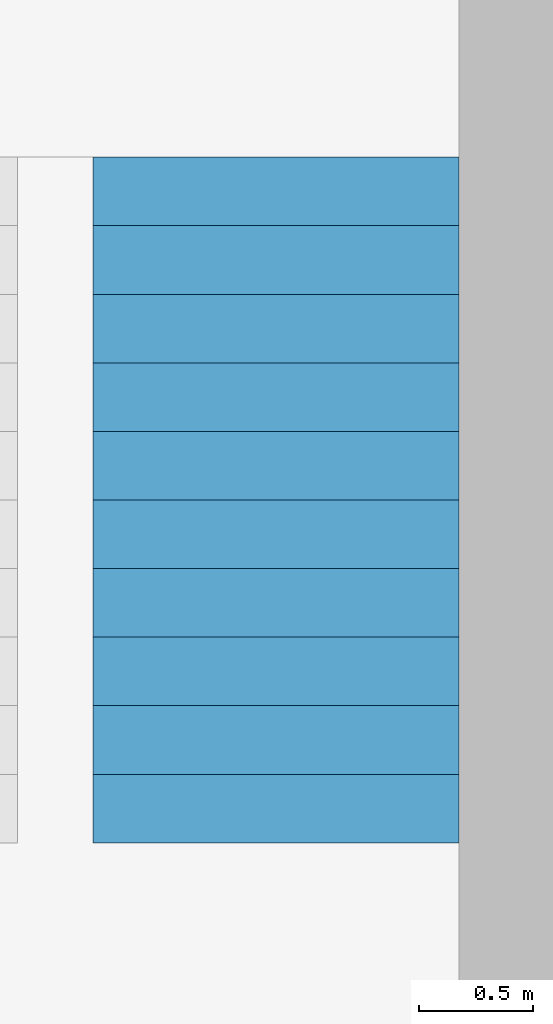
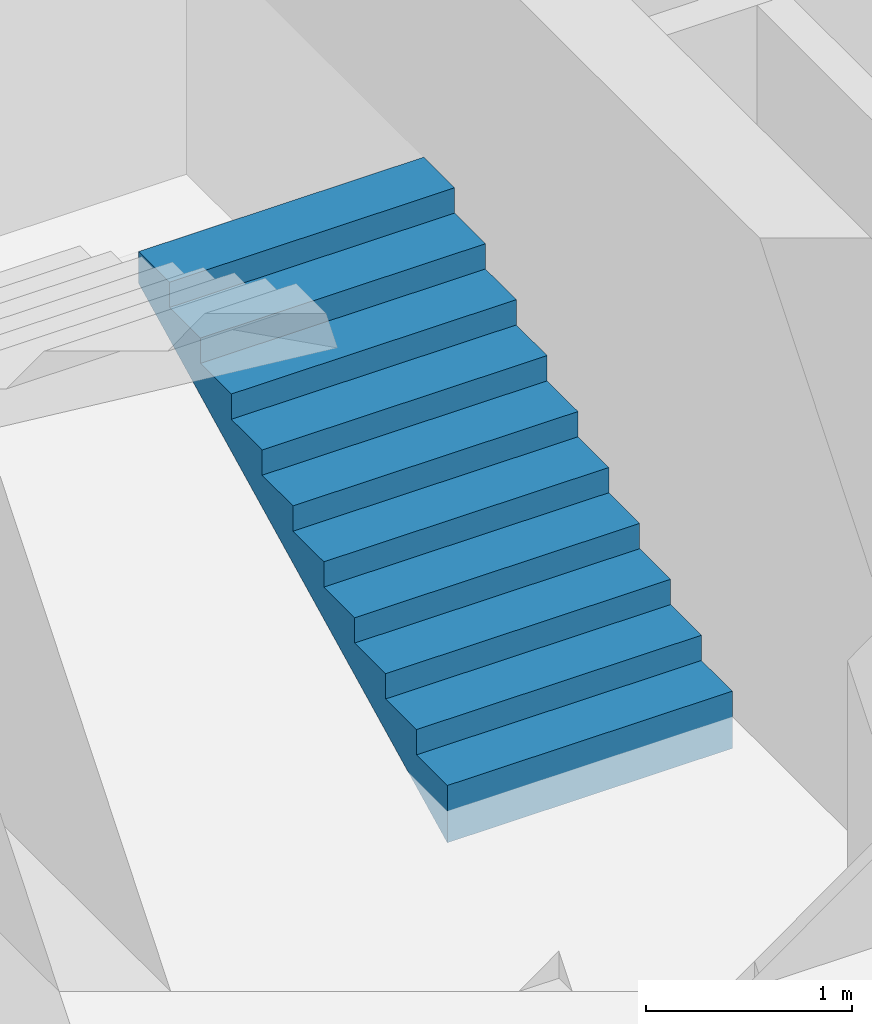
# One storey, part 2 of 5: 1 building element part, 1 element without a shape of its own.
"""IFC4 building model written with IfcOpenShell, lengths in metres."""

from ifc_helpers import new_model, entity, si_unit, converted_unit, derived_unit, direction, frame, origin_with_axes, place, context, subcontext, project, spatial, polygons, material, type_object, element, aggregate, save


model = new_model("IFC4")

# Units and contexts
model_context = context("Model", 3, precision=1e-05, world=origin_with_axes(), true_north=direction((0.0, 1.0)))
body_context = subcontext(model_context, "Body", "Model", "MODEL_VIEW")
ifc_project = project(units=[si_unit("LENGTHUNIT", "METRE"), si_unit("AREAUNIT", "SQUARE_METRE"), si_unit("VOLUMEUNIT", "CUBIC_METRE"), converted_unit("PLANEANGLEUNIT", "DEGREE", entity("IfcPlaneAngleMeasure", 0.0174532925199433), si_unit("PLANEANGLEUNIT", "RADIAN"), dimensions=[0, 0, 0, 0, 0, 0, 0]), converted_unit("TIMEUNIT", "Year", entity("IfcTimeMeasure", 31557600.0), si_unit("TIMEUNIT", "SECOND"), dimensions=[0, 0, 1, 0, 0, 0, 0]), si_unit("MASSUNIT", "GRAM", prefix="KILO"), si_unit("THERMODYNAMICTEMPERATUREUNIT", "DEGREE_CELSIUS"), si_unit("LUMINOUSINTENSITYUNIT", "LUMEN"), si_unit("ENERGYUNIT", "JOULE", prefix="MEGA"), derived_unit("THERMALCONDUCTANCEUNIT", [(si_unit("POWERUNIT", "WATT"), 1), (si_unit("LENGTHUNIT", "METRE"), -1), (si_unit("THERMODYNAMICTEMPERATUREUNIT", "KELVIN"), -1)]), derived_unit("SPECIFICHEATCAPACITYUNIT", [(si_unit("ENERGYUNIT", "JOULE"), 1), (si_unit("MASSUNIT", "GRAM", prefix="KILO"), -1), (si_unit("THERMODYNAMICTEMPERATUREUNIT", "KELVIN"), -1)]), derived_unit("MASSDENSITYUNIT", [(si_unit("MASSUNIT", "GRAM", prefix="KILO"), 1), (si_unit("VOLUMEUNIT", "CUBIC_METRE"), -1)])], contexts=[model_context])

# Site, building, storey
site_placement = place(None, origin_with_axes())
site = spatial("IfcSite", under=ifc_project, at=site_placement, CompositionType="ELEMENT")
building_placement = place(None, origin_with_axes())
building = spatial("IfcBuilding", under=site, at=building_placement, CompositionType="ELEMENT")
storey_placement = place(None, frame((0.0, 0.0, -3.0), z_axis=(0.0, 0.0, 1.0), x_axis=(1.0, 0.0, 0.0)))
storey = spatial("IfcBuildingStorey", under=building, at=storey_placement, Name="UG", CompositionType="ELEMENT", Elevation=-3.0)

# Stair, building element part
stair_type = type_object("IfcStairType", PredefinedType="NOTDEFINED")
stair_placement = place(None, frame((26.388, 9.02499994546755, -3.0), z_axis=(0.0, 0.0, 1.0), x_axis=(1.0, 0.0, 0.0)))
stair = element("IfcStair", 1, at=stair_placement, inside=storey, type_object=stair_type, Name="Treppe - 003", PredefinedType="NOTDEFINED")
ifc_material = material(Name="Stahlbeton Decke")
building_element_part_placement = place(None, frame((26.388, 9.02499994546755, -3.0), z_axis=(0.0, 0.0, 1.0), x_axis=(1.0, 0.0, 0.0)))
building_element_part = element("IfcBuildingElementPart", 2, at=building_element_part_placement, material=ifc_material, Name="Stahlbeton Decke", PredefinedType="NOTDEFINED", context=body_context, shape_type="Tessellation", body=[
    polygons([(1.6, 2.775, 1.19743422191252), (1.6, 2.85, 1.23493422191252), (1.6, 2.925, 1.27243422191252), (1.6, 3.0, 1.30993422191252), (1.6, 3.0, 1.5), (1.6, 2.7, 1.5), (1.6, 2.7, 1.35), (1.6, 2.4, 1.35), (1.6, 2.4, 1.2), (1.6, 2.1, 1.2), (1.6, 2.1, 1.05), (1.6, 1.8, 1.05), (1.6, 1.8, 0.9), (1.6, 1.5, 0.9), (1.6, 1.5, 0.75), (1.6, 1.2, 0.75), (1.6, 1.2, 0.6), (1.6, 0.899999999999999, 0.6), (1.6, 0.899999999999999, 0.45), (1.6, 0.6, 0.45), (1.6, 0.6, 0.3), (1.6, 0.3, 0.3), (1.6, 0.3, 0.15), (1.6, 0.0, 0.15), (1.6, 0.0, -0.190065778087482), (1.6, 0.0999999999999999, -0.140065778087482), (1.6, 0.2, -0.0900657780874821), (1.6, 0.3, -0.0400657780874822), (1.6, 0.4, 0.0099342219125178), (1.6, 0.5, 0.0599342219125178), (1.6, 0.6, 0.109934221912518), (1.6, 0.7, 0.159934221912518), (1.6, 0.8, 0.209934221912518), (1.6, 0.899999999999999, 0.259934221912518), (1.6, 0.975, 0.297434221912518), (1.6, 1.05, 0.334934221912518), (1.6, 1.125, 0.372434221912518), (1.6, 1.2, 0.409934221912518), (1.6, 1.275, 0.447434221912518), (1.6, 1.35, 0.484934221912518), (1.6, 1.425, 0.522434221912518), (1.6, 1.5, 0.559934221912518), (1.6, 1.575, 0.597434221912518), (1.6, 1.65, 0.634934221912518), (1.6, 1.725, 0.672434221912518), (1.6, 1.8, 0.709934221912518), (1.6, 1.9, 0.759934221912518), (1.6, 2.0, 0.809934221912518), (1.6, 2.1, 0.859934221912518), (1.6, 2.2, 0.909934221912518), (1.6, 2.3, 0.959934221912518), (1.6, 2.4, 1.00993422191252), (1.6, 2.5, 1.05993422191252), (1.6, 2.6, 1.10993422191252), (1.6, 2.7, 1.15993422191252), (0.0, 2.775, 1.19743422191252), (0.0, 2.85, 1.23493422191252), (0.0, 2.925, 1.27243422191252), (0.0, 3.0, 1.30993422191252), (0.0, 3.0, 1.5), (0.0, 2.7, 1.5), (0.0, 2.7, 1.35), (0.0, 2.4, 1.35), (0.0, 2.4, 1.2), (0.0, 2.1, 1.2), (0.0, 2.1, 1.05), (0.0, 1.8, 1.05), (0.0, 1.8, 0.9), (0.0, 1.5, 0.9), (0.0, 1.5, 0.75), (0.0, 1.2, 0.75), (0.0, 1.2, 0.6), (0.0, 0.899999999999999, 0.6), (0.0, 0.899999999999999, 0.45), (0.0, 0.6, 0.45), (0.0, 0.6, 0.3), (0.0, 0.3, 0.3), (0.0, 0.3, 0.15), (0.0, 0.0, 0.15), (0.0, 0.0, -0.190065778087482), (0.0, 0.0999999999999999, -0.140065778087482), (0.0, 0.2, -0.0900657780874821), (0.0, 0.3, -0.0400657780874822), (0.0, 0.4, 0.0099342219125178), (0.0, 0.5, 0.0599342219125178), (0.0, 0.6, 0.109934221912518), (0.0, 0.7, 0.159934221912518), (0.0, 0.8, 0.209934221912518), (0.0, 0.899999999999999, 0.259934221912518), (0.0, 0.975, 0.297434221912518), (0.0, 1.05, 0.334934221912518), (0.0, 1.125, 0.372434221912518), (0.0, 1.2, 0.409934221912518), (0.0, 1.275, 0.447434221912518), (0.0, 1.35, 0.484934221912518), (0.0, 1.425, 0.522434221912518), (0.0, 1.5, 0.559934221912518), (0.0, 1.575, 0.597434221912518), (0.0, 1.65, 0.634934221912518), (0.0, 1.725, 0.672434221912518), (0.0, 1.8, 0.709934221912518), (0.0, 1.9, 0.759934221912518), (0.0, 2.0, 0.809934221912518), (0.0, 2.1, 0.859934221912518), (0.0, 2.2, 0.909934221912518), (0.0, 2.3, 0.959934221912518), (0.0, 2.4, 1.00993422191252), (0.0, 2.5, 1.05993422191252), (0.0, 2.6, 1.10993422191252), (0.0, 2.7, 1.15993422191252)], [[[1, 2, 3, 4, 5, 6, 7, 8, 9, 10, 11, 12, 13, 14, 15, 16, 17, 18, 19, 20, 21, 22, 23, 24, 25, 26, 27, 28, 29, 30, 31, 32, 33, 34, 35, 36, 37, 38, 39, 40, 41, 42, 43, 44, 45, 46, 47, 48, 49, 50, 51, 52, 53, 54, 55]], [[56, 57, 2, 1]], [[57, 58, 3, 2]], [[58, 59, 4, 3]], [[5, 4, 59, 60]], [[5, 60, 61, 6]], [[61, 62, 7, 6]], [[62, 63, 8, 7]], [[9, 8, 63, 64]], [[64, 65, 10, 9]], [[11, 10, 65, 66]], [[66, 67, 12, 11]], [[13, 12, 67, 68]], [[68, 69, 14, 13]], [[15, 14, 69, 70]], [[70, 71, 16, 15]], [[17, 16, 71, 72]], [[72, 73, 18, 17]], [[19, 18, 73, 74]], [[74, 75, 20, 19]], [[21, 20, 75, 76]], [[76, 77, 22, 21]], [[23, 22, 77, 78]], [[78, 79, 24, 23]], [[24, 79, 80, 25]], [[80, 81, 26, 25]], [[81, 82, 27, 26]], [[82, 83, 28, 27]], [[83, 84, 29, 28]], [[84, 85, 30, 29]], [[85, 86, 31, 30]], [[86, 87, 32, 31]], [[87, 88, 33, 32]], [[88, 89, 34, 33]], [[89, 90, 35, 34]], [[90, 91, 36, 35]], [[91, 92, 37, 36]], [[92, 93, 38, 37]], [[93, 94, 39, 38]], [[94, 95, 40, 39]], [[95, 96, 41, 40]], [[96, 97, 42, 41]], [[97, 98, 43, 42]], [[98, 99, 44, 43]], [[99, 100, 45, 44]], [[100, 101, 46, 45]], [[101, 102, 47, 46]], [[102, 103, 48, 47]], [[103, 104, 49, 48]], [[104, 105, 50, 49]], [[105, 106, 51, 50]], [[106, 107, 52, 51]], [[107, 108, 53, 52]], [[108, 109, 54, 53]], [[109, 110, 55, 54]], [[110, 56, 1, 55]], [[83, 82, 81, 80, 79, 78, 77, 76, 75, 74, 73, 72, 71, 70, 69, 68, 67, 66, 65, 64, 63, 62, 61, 60, 59, 58, 57, 56, 110, 109, 108, 107, 106, 105, 104, 103, 102, 101, 100, 99, 98, 97, 96, 95, 94, 93, 92, 91, 90, 89, 88, 87, 86, 85, 84]]], closed=True),
])
aggregate(stair, [building_element_part])

save(model, "model.ifc")
